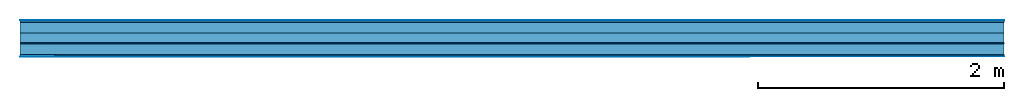
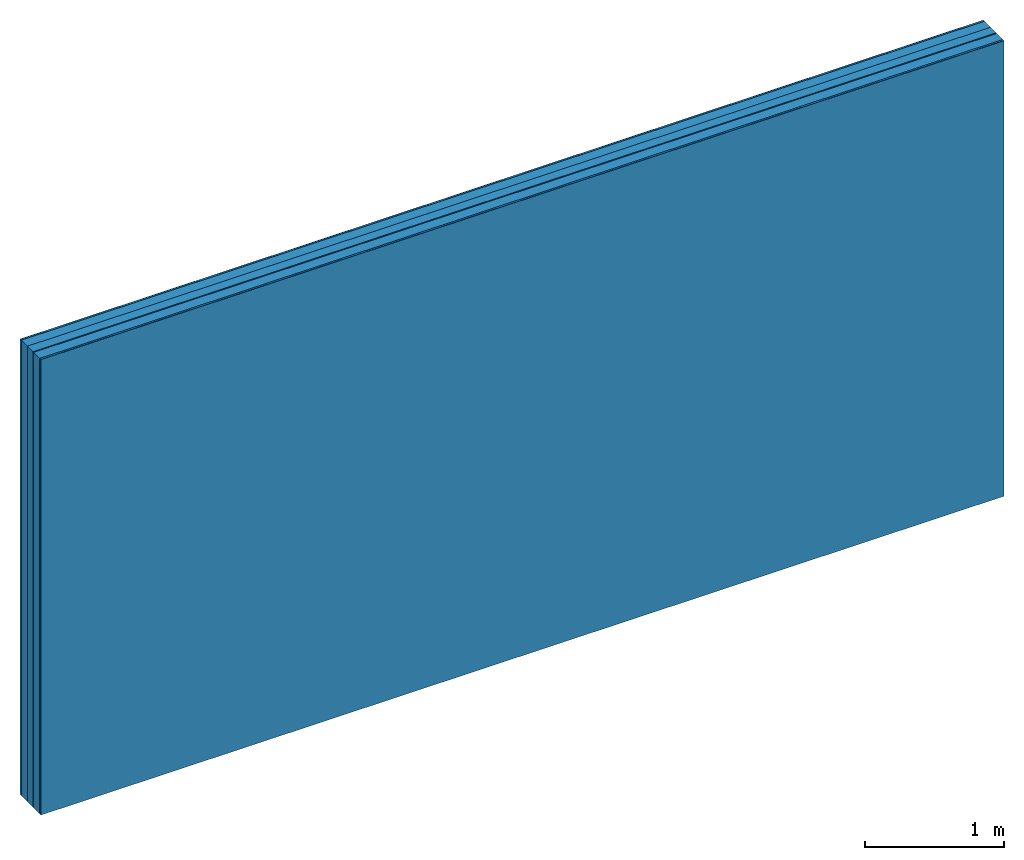
# One storey: 6 plates, 2 members, 1 element without a shape of its own.
"""IFC4 building model written with IfcOpenShell, lengths in metres."""

import ifcopenshell
import ifcopenshell.guid

model = None  # the IFC model being written
_history = None  # IfcOwnerHistory: only IFC2X3 demands one
_inside = {}  # id of a spatial element -> (the spatial element, [elements in it])
_under = {}  # id of a project, library or spatial element -> (it, [spatial elements below it])
_declared = {}  # id of a project -> (the project, [libraries it declares])
_typed = {}  # id of a type object -> (the type object, [elements of that type])
_made_of = {}  # id of a material, layer set ... -> (it, [elements and type objects made of it])


def new_model(schema):
    """Start an empty IFC model of exactly this schema.

    Asked for "IFC4X3", IfcOpenShell would pick the latest addendum, in which some entities
    have other attributes; the version numbers below select the first issue.
    IFC2X3 requires an IfcOwnerHistory on every rooted entity: one is made here for all.
    """
    global model, _history
    if schema == "IFC4X3":
        model = ifcopenshell.file(schema_version=(4, 3, 0, 0))
    else:
        model = ifcopenshell.file(schema=schema)
    _inside.clear()
    _under.clear()
    _declared.clear()
    _typed.clear()
    _made_of.clear()
    _history = None
    if model.schema == "IFC2X3":
        org = make("IfcOrganization", Name="unknown")
        user = make(
            "IfcPersonAndOrganization",
            ThePerson=make("IfcPerson", FamilyName="unknown"),
            TheOrganization=org,
        )
        app = make(
            "IfcApplication",
            ApplicationDeveloper=org,
            Version="unknown",
            ApplicationFullName="unknown",
            ApplicationIdentifier="unknown",
        )
        _history = make(
            "IfcOwnerHistory",
            OwningUser=user,
            OwningApplication=app,
            ChangeAction="ADDED",
            CreationDate=0,
        )
    return model


def make(cls, **values):
    """One entity of the class cls with the attributes given. An attribute that is None is left unset."""
    return model.create_entity(
        cls, **{name: value for name, value in values.items() if value is not None}
    )


def rooted(cls, **values):
    """An entity with a GlobalId (a new one), such as an element, a storey or a relation."""
    return make(cls, GlobalId=ifcopenshell.guid.new(), OwnerHistory=_history, **values)


def si_unit(unit_type, name, prefix=None):
    """IfcSIUnit, for example si_unit("LENGTHUNIT", "METRE", prefix="MILLI")."""
    return make("IfcSIUnit", UnitType=unit_type, Prefix=prefix, Name=name)


def derived_unit(unit_type, elements):
    """IfcDerivedUnit: a product of units, each with its exponent."""
    return make(
        "IfcDerivedUnit",
        Elements=[
            make("IfcDerivedUnitElement", Unit=unit, Exponent=power)
            for unit, power in elements
        ],
        UnitType=unit_type,
    )


def assignment(units):
    """IfcUnitAssignment: the units of a project."""
    return None if units is None else make("IfcUnitAssignment", Units=units)


def point(xyz):
    """IfcCartesianPoint."""
    return None if xyz is None else make("IfcCartesianPoint", Coordinates=xyz)


def direction(xyz):
    """IfcDirection."""
    return None if xyz is None else make("IfcDirection", DirectionRatios=xyz)


def frame(location, z_axis=None, x_axis=None):
    """IfcAxis2Placement3D, a coordinate frame: its origin and axes. An axis left out is left unset."""
    return make(
        "IfcAxis2Placement3D",
        Location=point(location),
        Axis=direction(z_axis),
        RefDirection=direction(x_axis),
    )


def frame_2d(location, x_axis=None):
    """IfcAxis2Placement2D, a coordinate frame in the plane: its origin and x axis."""
    return make(
        "IfcAxis2Placement2D", Location=point(location), RefDirection=direction(x_axis)
    )


def origin():
    """The frame at (0, 0, 0) with its axes left unset."""
    return frame((0.0, 0.0, 0.0))


def origin_with_axes():
    """The frame at (0, 0, 0) with the z axis (0, 0, 1) and the x axis (1, 0, 0) written out."""
    return frame((0.0, 0.0, 0.0), z_axis=(0.0, 0.0, 1.0), x_axis=(1.0, 0.0, 0.0))


def place(relative_to, where):
    """IfcLocalPlacement: puts the frame where relative to a parent placement (None: the world)."""
    return make(
        "IfcLocalPlacement", PlacementRelTo=relative_to, RelativePlacement=where
    )


def context(
    kind, dimensions, precision=None, world=None, true_north=None, identifier=None
):
    """IfcGeometricRepresentationContext, for example the 3D "Model" context."""
    return make(
        "IfcGeometricRepresentationContext",
        ContextIdentifier=identifier,
        ContextType=kind,
        CoordinateSpaceDimension=dimensions,
        Precision=precision,
        WorldCoordinateSystem=world,
        TrueNorth=true_north,
    )


def project(units=None, contexts=None):
    """IfcProject with its units and contexts."""
    return rooted(
        "IfcProject",
        Name="project",
        RepresentationContexts=contexts,
        UnitsInContext=assignment(units),
    )


def spatial(cls, under=None, at=None, **own):
    """A site, building, storey or space (cls), placed at a placement, below another one or the project."""
    s = rooted(cls, ObjectPlacement=at, **own)
    if under is not None:
        _under.setdefault(under.id(), (under, []))[1].append(s)
    return s


def profile(cls, at=None, kind="AREA", **sizes):
    """A parametric profile (cls). Its sizes go by their IFC names, for example OverallWidth=200.0."""
    return make(cls, ProfileType=kind, Position=at, **sizes)


def rectangle(**sizes):
    """IfcRectangleProfileDef."""
    return profile("IfcRectangleProfileDef", **sizes)


def extrude(swept, where, along, depth):
    """IfcExtrudedAreaSolid: the profile swept, set in the frame where, extruded along a direction by depth."""
    return make(
        "IfcExtrudedAreaSolid",
        SweptArea=swept,
        Position=where,
        ExtrudedDirection=direction(along),
        Depth=depth,
    )


def shape(context_of_items, identifier, shape_type, items):
    """IfcShapeRepresentation: the items that make up one representation, for example the "Body"."""
    return make(
        "IfcShapeRepresentation",
        ContextOfItems=context_of_items,
        RepresentationIdentifier=identifier,
        RepresentationType=shape_type,
        Items=items,
    )


def material(Name=None, Category=None):
    """IfcMaterial."""
    return make("IfcMaterial", Name=Name, Category=Category)


def layer(
    of_material, thickness, ventilated=None, Name=None, Category=None, Priority=None
):
    """IfcMaterialLayer: one layer of a wall or slab, of a material (None: an air gap)."""
    return make(
        "IfcMaterialLayer",
        Material=of_material,
        LayerThickness=thickness,
        IsVentilated=ventilated,
        Name=Name,
        Category=Category,
        Priority=Priority,
    )


def layer_set(layers, Name=None):
    """IfcMaterialLayerSet."""
    return make("IfcMaterialLayerSet", MaterialLayers=layers, LayerSetName=Name)


def made_of(thing, what):
    """Note that an element or type object is made of a material, layer set ...; save() writes the relation."""
    if what is not None:
        _made_of.setdefault(what.id(), (what, []))[1].append(thing)
    return thing


def type_object(cls, material=None, **own):
    """A type object (cls), such as IfcWallType, which elements share."""
    return made_of(rooted(cls, **own), material)


def element(
    cls,
    number,
    at=None,
    inside=None,
    cuts=None,
    type_object=None,
    material=None,
    context=None,
    identifier="Body",
    shape_type=None,
    held_by="IfcProductDefinitionShape",
    body=None,
    shapes=None,
    **own,
):
    """One element of the class cls, such as IfcWall. Its Tag is "e" and its number.

    at: its placement. inside: the storey or other place that contains it. cuts: it is an
    opening in that element (IfcRelVoidsElement). A single representation is given by context,
    identifier, shape_type and body (its items); several are given by shapes. held_by: the class
    of the entity that holds the representations. save() writes the other relations.
    """
    e = rooted(cls, Tag="e%d" % number, ObjectPlacement=at, **own)
    if body is not None:
        shapes = [shape(context, identifier, shape_type, body)]
    if shapes is not None:
        e.Representation = make(held_by, Representations=shapes)
    if inside is not None:
        _inside.setdefault(inside.id(), (inside, []))[1].append(e)
    if cuts is not None:
        rooted(
            "IfcRelVoidsElement", RelatingBuildingElement=cuts, RelatedOpeningElement=e
        )
    if type_object is not None:
        _typed.setdefault(type_object.id(), (type_object, []))[1].append(e)
    return made_of(e, material)


def aggregate(whole, parts):
    """IfcRelAggregates: a whole, such as a stair, and the parts it consists of."""
    return rooted("IfcRelAggregates", RelatingObject=whole, RelatedObjects=parts)


def save(model, path):
    """Write the relations noted so far, then the file.

    IfcRelAggregates (storeys below a building ...), IfcRelContainedInSpatialStructure (elements
    in a storey), IfcRelDefinesByType, IfcRelAssociatesMaterial and IfcRelDeclares: one each for
    every whole, place, type object, material and project.
    """
    for whole, parts in _under.values():
        aggregate(whole, parts)
    for where, things in _inside.values():
        rooted(
            "IfcRelContainedInSpatialStructure",
            RelatedElements=things,
            RelatingStructure=where,
        )
    for kind, things in _typed.values():
        rooted("IfcRelDefinesByType", RelatedObjects=things, RelatingType=kind)
    for what, things in _made_of.values():
        rooted("IfcRelAssociatesMaterial", RelatedObjects=things, RelatingMaterial=what)
    for by, libraries in _declared.values():
        rooted("IfcRelDeclares", RelatingContext=by, RelatedDefinitions=libraries)
    model.write(path)


model = new_model("IFC4")

# Units and contexts
plan_context = context("Plan", 3, precision=1e-05, world=origin(), true_north=direction((0.0, 1.0)))
model_context = context("Model", 3, precision=1e-05, world=origin(), true_north=direction((0.0, 1.0)))
ifc_project = project(units=[si_unit("LENGTHUNIT", "METRE"), derived_unit("SOUNDPRESSUREUNIT", [(si_unit("PRESSUREUNIT", "PASCAL", prefix="MICRO"), 0)]), si_unit("ENERGYUNIT", "JOULE", prefix="MEGA"), si_unit("MASSUNIT", "GRAM", prefix="KILO"), derived_unit("THERMALTRANSMITTANCEUNIT", [(si_unit("POWERUNIT", "WATT"), 1), (si_unit("AREAUNIT", "SQUARE_METRE"), -1), (si_unit("THERMODYNAMICTEMPERATUREUNIT", "KELVIN"), -1)]), derived_unit("AREADENSITYUNIT", [(si_unit("MASSUNIT", "GRAM", prefix="KILO"), 1), (si_unit("AREAUNIT", "SQUARE_METRE"), -1)]), derived_unit("USERDEFINED", [(si_unit("ENERGYUNIT", "JOULE", prefix="MEGA"), 1), (si_unit("AREAUNIT", "SQUARE_METRE"), -1)])], contexts=[plan_context, model_context])

# Site, building, storey
site = spatial("IfcSite", under=ifc_project)
building_placement = place(None, origin())
building = spatial("IfcBuilding", under=site, at=building_placement)
storey_placement = place(building_placement, origin())
storey = spatial("IfcBuildingStorey", under=building, at=storey_placement)

# Wall, members, plates
ifc_material_1 = material(Category="04.001")
ifc_layer_1 = layer(ifc_material_1, 0.003, Name="Surface")
ifc_material_2 = material(Name="DFH2IR Knauf Diamant hard- plasterboard", Category="03.007")
ifc_layer_2 = layer(ifc_material_2, 0.015, Name="room side 1st layer")
ifc_material_3 = material(Name="of the art")
ifc_layer_3 = layer(ifc_material_3, 0.0, Name="Bond")
ifc_layer_4 = layer(None, 0.087, Name="Support")
ifc_layer_5 = layer(ifc_material_3, 0.0, Name="Bond")
ifc_material_4 = material(Category="10.008")
ifc_layer_6 = layer(ifc_material_4, 0.08, Name="Intermediate insulation")
ifc_material_5 = material(Name="Air")
ifc_layer_7 = layer(ifc_material_5, 0.01, Name="Air gap")
ifc_layer_8 = layer(ifc_material_3, 0.0, Name="Bond")
ifc_layer_9 = layer(None, 0.087, Name="Support")
ifc_layer_10 = layer(ifc_material_3, 0.0, Name="Bond")
ifc_layer_11 = layer(ifc_material_2, 0.015, Name="room side 1st layer")
ifc_layer_12 = layer(ifc_material_1, 0.003, Name="Surface")
ifc_layer_set = layer_set([ifc_layer_1, ifc_layer_2, ifc_layer_3, ifc_layer_4, ifc_layer_5, ifc_layer_6, ifc_layer_7, ifc_layer_8, ifc_layer_9, ifc_layer_10, ifc_layer_11, ifc_layer_12])
wall_type = type_object("IfcWallType", Name="B0266", PredefinedType="NOTDEFINED", material=ifc_layer_set)
wall_placement = place(None, frame((0.0, 0.0, 0.0), z_axis=(0.0, -1.0, 0.0), x_axis=(1.0, 0.0, 0.0)))
wall = element("IfcWall", 1, at=wall_placement, inside=storey, type_object=wall_type, material=ifc_layer_set, Name="Wall #1")
ifc_material_6 = material(Name="Solid timber panel")
member_1_placement = place(wall_placement, origin())
member_1 = element("IfcMember", 2, at=member_1_placement, material=ifc_material_6, Name="Support", context=plan_context, shape_type="SweptSolid", body=[
    extrude(rectangle(XDim=1.0, YDim=0.087, at=frame_2d((0.5, 0.0435), x_axis=(1.0, 0.0))), frame((0.0, 4.0, 0.018), z_axis=(0.0, -1.0, 0.0), x_axis=(1.0, 0.0, 0.0)), (0.0, 0.0, 1.0), 4.0),
    extrude(rectangle(XDim=1.0, YDim=0.087, at=frame_2d((0.5, 0.0435), x_axis=(1.0, 0.0))), frame((1.0, 4.0, 0.018), z_axis=(0.0, -1.0, 0.0), x_axis=(1.0, 0.0, 0.0)), (0.0, 0.0, 1.0), 4.0),
    extrude(rectangle(XDim=1.0, YDim=0.087, at=frame_2d((0.5, 0.0435), x_axis=(1.0, 0.0))), frame((2.0, 4.0, 0.018), z_axis=(0.0, -1.0, 0.0), x_axis=(1.0, 0.0, 0.0)), (0.0, 0.0, 1.0), 4.0),
    extrude(rectangle(XDim=1.0, YDim=0.087, at=frame_2d((0.5, 0.0435), x_axis=(1.0, 0.0))), frame((3.0, 4.0, 0.018), z_axis=(0.0, -1.0, 0.0), x_axis=(1.0, 0.0, 0.0)), (0.0, 0.0, 1.0), 4.0),
    extrude(rectangle(XDim=1.0, YDim=0.087, at=frame_2d((0.5, 0.0435), x_axis=(1.0, 0.0))), frame((4.0, 4.0, 0.018), z_axis=(0.0, -1.0, 0.0), x_axis=(1.0, 0.0, 0.0)), (0.0, 0.0, 1.0), 4.0),
    extrude(rectangle(XDim=1.0, YDim=0.087, at=frame_2d((0.5, 0.0435), x_axis=(1.0, 0.0))), frame((5.0, 4.0, 0.018), z_axis=(0.0, -1.0, 0.0), x_axis=(1.0, 0.0, 0.0)), (0.0, 0.0, 1.0), 4.0),
    extrude(rectangle(XDim=1.0, YDim=0.087, at=frame_2d((0.5, 0.0435), x_axis=(1.0, 0.0))), frame((6.0, 4.0, 0.018), z_axis=(0.0, -1.0, 0.0), x_axis=(1.0, 0.0, 0.0)), (0.0, 0.0, 1.0), 4.0),
    extrude(rectangle(XDim=1.0, YDim=0.087, at=frame_2d((0.5, 0.0435), x_axis=(1.0, 0.0))), frame((7.0, 4.0, 0.018), z_axis=(0.0, -1.0, 0.0), x_axis=(1.0, 0.0, 0.0)), (0.0, 0.0, 1.0), 4.0),
])
member_2_placement = place(wall_placement, origin())
member_2 = element("IfcMember", 3, at=member_2_placement, material=ifc_material_6, Name="Support", context=plan_context, shape_type="SweptSolid", body=[
    extrude(rectangle(XDim=1.0, YDim=0.087, at=frame_2d((0.5, 0.0435), x_axis=(1.0, 0.0))), frame((0.0, 4.0, 0.195), z_axis=(0.0, -1.0, 0.0), x_axis=(1.0, 0.0, 0.0)), (0.0, 0.0, 1.0), 4.0),
    extrude(rectangle(XDim=1.0, YDim=0.087, at=frame_2d((0.5, 0.0435), x_axis=(1.0, 0.0))), frame((1.0, 4.0, 0.195), z_axis=(0.0, -1.0, 0.0), x_axis=(1.0, 0.0, 0.0)), (0.0, 0.0, 1.0), 4.0),
    extrude(rectangle(XDim=1.0, YDim=0.087, at=frame_2d((0.5, 0.0435), x_axis=(1.0, 0.0))), frame((2.0, 4.0, 0.195), z_axis=(0.0, -1.0, 0.0), x_axis=(1.0, 0.0, 0.0)), (0.0, 0.0, 1.0), 4.0),
    extrude(rectangle(XDim=1.0, YDim=0.087, at=frame_2d((0.5, 0.0435), x_axis=(1.0, 0.0))), frame((3.0, 4.0, 0.195), z_axis=(0.0, -1.0, 0.0), x_axis=(1.0, 0.0, 0.0)), (0.0, 0.0, 1.0), 4.0),
    extrude(rectangle(XDim=1.0, YDim=0.087, at=frame_2d((0.5, 0.0435), x_axis=(1.0, 0.0))), frame((4.0, 4.0, 0.195), z_axis=(0.0, -1.0, 0.0), x_axis=(1.0, 0.0, 0.0)), (0.0, 0.0, 1.0), 4.0),
    extrude(rectangle(XDim=1.0, YDim=0.087, at=frame_2d((0.5, 0.0435), x_axis=(1.0, 0.0))), frame((5.0, 4.0, 0.195), z_axis=(0.0, -1.0, 0.0), x_axis=(1.0, 0.0, 0.0)), (0.0, 0.0, 1.0), 4.0),
    extrude(rectangle(XDim=1.0, YDim=0.087, at=frame_2d((0.5, 0.0435), x_axis=(1.0, 0.0))), frame((6.0, 4.0, 0.195), z_axis=(0.0, -1.0, 0.0), x_axis=(1.0, 0.0, 0.0)), (0.0, 0.0, 1.0), 4.0),
    extrude(rectangle(XDim=1.0, YDim=0.087, at=frame_2d((0.5, 0.0435), x_axis=(1.0, 0.0))), frame((7.0, 4.0, 0.195), z_axis=(0.0, -1.0, 0.0), x_axis=(1.0, 0.0, 0.0)), (0.0, 0.0, 1.0), 4.0),
])
plate_1_placement = place(wall_placement, origin())
plate_1 = element("IfcPlate", 4, at=plate_1_placement, material=ifc_material_1, Name="Surface", context=plan_context, shape_type="SweptSolid", body=[
    extrude(rectangle(XDim=8.0, YDim=4.0, at=frame_2d((4.0, 2.0), x_axis=(1.0, 0.0))), origin_with_axes(), (0.0, 0.0, 1.0), 0.003),
])
plate_2_placement = place(wall_placement, origin())
plate_2 = element("IfcPlate", 5, at=plate_2_placement, material=ifc_material_2, Name="room side 1st layer", context=plan_context, shape_type="SweptSolid", body=[
    extrude(rectangle(XDim=8.0, YDim=4.0, at=frame_2d((4.0, 2.0), x_axis=(1.0, 0.0))), frame((0.0, 0.0, 0.003), z_axis=(0.0, 0.0, 1.0), x_axis=(1.0, 0.0, 0.0)), (0.0, 0.0, 1.0), 0.015),
])
plate_3_placement = place(wall_placement, origin())
plate_3 = element("IfcPlate", 6, at=plate_3_placement, material=ifc_material_4, Name="Intermediate insulation", context=plan_context, shape_type="SweptSolid", body=[
    extrude(rectangle(XDim=8.0, YDim=4.0, at=frame_2d((4.0, 2.0), x_axis=(1.0, 0.0))), frame((0.0, 0.0, 0.105), z_axis=(0.0, 0.0, 1.0), x_axis=(1.0, 0.0, 0.0)), (0.0, 0.0, 1.0), 0.08),
])
plate_4_placement = place(wall_placement, origin())
plate_4 = element("IfcPlate", 7, at=plate_4_placement, material=ifc_material_5, Name="Air gap", context=plan_context, shape_type="SweptSolid", body=[
    extrude(rectangle(XDim=8.0, YDim=4.0, at=frame_2d((4.0, 2.0), x_axis=(1.0, 0.0))), frame((0.0, 0.0, 0.185), z_axis=(0.0, 0.0, 1.0), x_axis=(1.0, 0.0, 0.0)), (0.0, 0.0, 1.0), 0.01),
])
plate_5_placement = place(wall_placement, origin())
plate_5 = element("IfcPlate", 8, at=plate_5_placement, material=ifc_material_2, Name="room side 1st layer", context=plan_context, shape_type="SweptSolid", body=[
    extrude(rectangle(XDim=8.0, YDim=4.0, at=frame_2d((4.0, 2.0), x_axis=(1.0, 0.0))), frame((0.0, 0.0, 0.282), z_axis=(0.0, 0.0, 1.0), x_axis=(1.0, 0.0, 0.0)), (0.0, 0.0, 1.0), 0.015),
])
plate_6_placement = place(wall_placement, origin())
plate_6 = element("IfcPlate", 9, at=plate_6_placement, material=ifc_material_1, Name="Surface", context=plan_context, shape_type="SweptSolid", body=[
    extrude(rectangle(XDim=8.0, YDim=4.0, at=frame_2d((4.0, 2.0), x_axis=(1.0, 0.0))), frame((0.0, 0.0, 0.297), z_axis=(0.0, 0.0, 1.0), x_axis=(1.0, 0.0, 0.0)), (0.0, 0.0, 1.0), 0.003),
])
aggregate(wall, [plate_1, plate_2, member_1, plate_3, plate_4, member_2, plate_5, plate_6])

save(model, "model.ifc")
